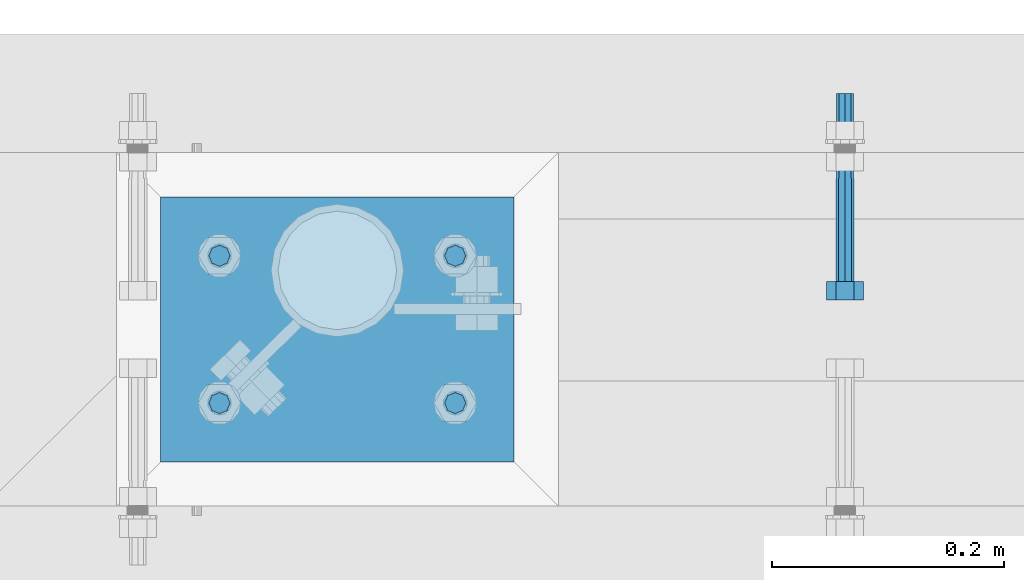
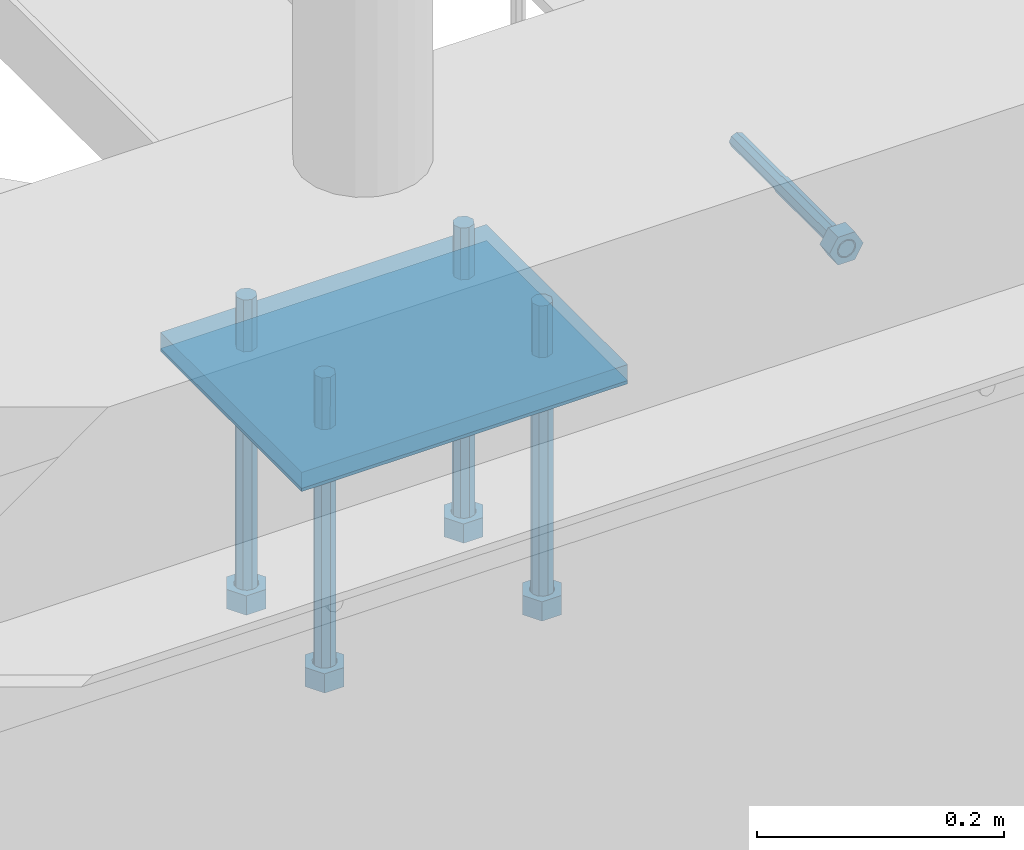
# One storey, part 431 of 975: 7 beams.
"""IFC2X3 building model written with IfcOpenShell, lengths in millimetres."""

from ifc_helpers import new_model, si_unit, frame, origin_with_axes, place, context, subcontext, project, spatial, faceted_brep, material, type_object, element, save


model = new_model("IFC2X3")

# Units and contexts
model_context = context("Model", 3, precision=1e-05, world=origin_with_axes())
body_context = subcontext(model_context, "Body", "Model", "MODEL_VIEW")
ifc_project = project(units=[si_unit("LENGTHUNIT", "METRE", prefix="MILLI"), si_unit("AREAUNIT", "SQUARE_METRE"), si_unit("VOLUMEUNIT", "CUBIC_METRE"), si_unit("MASSUNIT", "GRAM", prefix="KILO"), si_unit("TIMEUNIT", "SECOND"), si_unit("PLANEANGLEUNIT", "RADIAN"), si_unit("SOLIDANGLEUNIT", "STERADIAN"), si_unit("THERMODYNAMICTEMPERATUREUNIT", "DEGREE_CELSIUS"), si_unit("LUMINOUSINTENSITYUNIT", "LUMEN")], contexts=[model_context])

# Site, building, storey
site_placement = place(None, origin_with_axes())
site = spatial("IfcSite", under=ifc_project, at=site_placement, CompositionType="ELEMENT")
building_placement = place(site_placement, origin_with_axes())
building = spatial("IfcBuilding", under=site, at=building_placement, Name="Undefined", CompositionType="ELEMENT")
storey_placement = place(building_placement, origin_with_axes())
storey = spatial("IfcBuildingStorey", under=building, at=storey_placement, Name="Undefined", CompositionType="ELEMENT", Elevation=0.0)

# Beams
ifc_material_1 = material(Name="STEEL/F1554-36")
beam_type_1 = type_object("IfcBeamType", PredefinedType="NOTDEFINED")
beam_1_placement = place(storey_placement, frame((7854.42084018762, 20726.3999996637, 3886.2), z_axis=(0.0, 0.0, 1.0), x_axis=(0.0, -1.0, 0.0)))
element("IfcBeam", 1, at=beam_1_placement, inside=storey, type_object=beam_type_1, material=ifc_material_1, Name="HEADED_ANCHOR_BOLT", context=body_context, shape_type="Brep", body=[
    faceted_brep([(88.9000000184824, 7.94000001861696, -13.7499999799138), (88.8999999527368, 15.8800000758411, 2.00943759409711e-08), (104.774999952569, 15.8800001213949, 6.97191353538074e-08), (104.775000018315, 7.94000006417082, -13.7499999302891), (88.900000064019, -7.94000009583215, -13.7499999799147), (104.775000063852, -7.9400000502792, -13.74999993029), (88.9000000438027, -15.880000153059, 2.00925569515675e-08), (104.775000043643, -15.8800001075042, 6.9716406869702e-08), (88.8999999780608, -7.94000009583488, 13.7500000200998), (104.774999977893, -7.94000005028101, 13.7500000697237), (88.8999999325279, 7.94000001861514, 13.7500000201007), (104.774999932361, 7.940000064169, 13.7500000697246), (88.9000000119959, 3.78780480527439, -7.86545778426807), (88.8999999957159, 6.82538844544797, -5.4430656647246), (88.8999999799416, 8.51112018845743, -1.94260763148395), (88.8999999677944, 8.51112018845652, 1.94260767167179), (88.8999999616899, 6.82538844544615, 5.44306570491244), (88.8999999628249, 3.78780480527257, 7.86545782445592), (88.8999999709849, -3.86089595849626e-08, 8.72999956233434), (88.8999999845473, -3.7878048824914, 7.8654578244541), (88.9000000008309, -6.82538852266407, 5.44306570491153), (88.9000000166052, -8.51112026567444, 1.94260767166998), (88.9000000287488, -8.51112026567353, -1.94260763148577), (88.9000000348606, -6.82538852266407, -5.44306566472642), (88.9000000337182, -3.78780488248958, -7.86545778426898), (88.9000000255583, -3.86080500902608e-08, -8.72999952214832), (104.775000025395, 6.94581103743985e-09, -8.72999947252447), (104.775000011829, 3.78780485082825, -7.86545773464422), (104.774999995549, 6.82538849100092, -5.44306561510075), (104.774999979774, 8.51112023401038, -1.9426075818601), (104.774999967627, 8.51112023401038, 1.94260772129564), (104.774999961523, 6.82538849100092, 5.44306575453629), (104.774999962658, 3.78780485082643, 7.86545787407977), (104.774999970818, 6.94399204803631e-09, 8.7299996119591), (104.77499998438, -3.78780483693754, 7.86545787407886), (104.775000000664, -6.82538847711112, 5.44306575453538), (104.775000016438, -8.51112022012057, 1.94260772129473), (104.775000028581, -8.51112022012057, -1.94260758186101), (104.775000034693, -6.82538847711021, -5.44306561510166), (104.775000033551, -3.78780483693663, -7.86545773464422), (-2.99107341561466e-07, -5.61266007567065, 5.61266007566792), (-4.22995071858168e-07, -7.93750000000728, 0.0), (104.774999998088, -7.93749999999, -4.45652403868735e-11), (104.774999998088, -5.61266007565791, 5.61266007562426), (-1.09139364212751e-11, 1.81898940354586e-12, 7.9375), (104.774999998095, 1.18234311230481e-11, 7.93749999995816), (2.99089151667431e-07, 5.61266007567428, 5.61266007566792), (104.774999998102, 5.61266007568065, 5.61266007562517), (4.22980519942939e-07, 7.93750000001091, 0.0), (104.77499999811, 7.93750000001364, -4.36557456851006e-11), (2.99089151667431e-07, 5.61266007567428, -5.61266007566792), (104.774999998102, 5.61266007568156, -5.61266007571339), (-1.09139364212751e-11, 1.81898940354586e-12, -7.9375), (104.774999998099, 1.2732925824821e-11, -7.93750000004547), (-73.0249999592124, 5.05157065939329, -5.0515715445581), (-73.0249999269472, -1.85405951924622e-07, -7.14400069976364), (-73.0249999328516, -5.0515710302052, -5.05157154455992), (-73.0249999734697, -7.14400018541073, -6.9975976657588e-07), (-73.0250000250016, -5.05157103020611, 5.05157014504039), (-73.0250000572705, -1.85406861419324e-07, 7.1439993002441), (-73.0250000513661, 5.05157065939238, 5.05157014503948), (-73.025000010748, 7.14399981459792, -6.99758857081179e-07), (0.00625003290042514, 5.05157085007795, -5.05157087849238), (0.00625006516929716, 5.27870724909008e-09, -7.1440000336961), (0.00625005926485755, -5.05157083952145, -5.05157087849329), (0.00625001864682417, -7.14399999472516, -3.36940502165817e-08), (0.00624996711121639, -5.05157083952145, 5.05157081110519), (0.00624993484598235, 5.2777977543883e-09, 7.14399996631164), (0.00624994074678398, 5.05157085007704, 5.05157081110701), (0.00624998136845534, 7.14400000528167, -3.36922312271781e-08), (-2.99107341561466e-07, -5.61266007567065, -5.61266007566792), (104.774999998092, -5.612660075657, -5.6126600757143)], [[[0, 1, 2, 3]], [[4, 0, 3, 5]], [[6, 4, 5, 7]], [[8, 6, 7, 9]], [[10, 8, 9, 11]], [[0, 4, 6, 8, 10, 1], [12, 13, 14, 15, 16, 17, 18, 19, 20, 21, 22, 23, 24, 25]], [[12, 25, 26, 27]], [[13, 12, 27, 28]], [[14, 13, 28, 29]], [[15, 14, 29, 30]], [[16, 15, 30, 31]], [[17, 16, 31, 32]], [[18, 17, 32, 33]], [[19, 18, 33, 34]], [[20, 19, 34, 35]], [[21, 20, 35, 36]], [[22, 21, 36, 37]], [[23, 22, 37, 38]], [[24, 23, 38, 39]], [[25, 24, 39, 26]], [[9, 7, 5, 3, 2, 11], [38, 37, 36, 35, 34, 33, 32, 31, 30, 29, 28, 27, 26, 39]], [[1, 10, 11, 2]], [[40, 41, 42, 43]], [[44, 40, 43, 45]], [[46, 44, 45, 47]], [[48, 46, 47, 49]], [[50, 48, 49, 51]], [[52, 50, 51, 53]], [[54, 55, 56, 57, 58, 59, 60, 61]], [[55, 54, 62, 63]], [[56, 55, 63, 64]], [[57, 56, 64, 65]], [[58, 57, 65, 66]], [[59, 58, 66, 67]], [[60, 59, 67, 68]], [[61, 60, 68, 69]], [[54, 61, 69, 62]], [[40, 44, 46, 48, 50, 52, 70, 41], [68, 67, 66, 65, 64, 63, 62, 69]], [[41, 70, 71, 42]], [[53, 51, 49, 47, 45, 43, 42, 71]], [[70, 52, 53, 71]]]),
])
beam_type_2 = type_object("IfcBeamType", PredefinedType="NOTDEFINED")
beam_2_placement = place(storey_placement, frame((7518.40000117523, 20659.7249986259, 3917.95), z_axis=(0.0, -1.0, 0.0), x_axis=(0.0, 0.0, -1.0)))
element("IfcBeam", 2, at=beam_2_placement, inside=storey, type_object=beam_type_2, material=ifc_material_1, Name="HEADED_BOLT", context=body_context, shape_type="Brep", body=[
    faceted_brep([(196.84375, -9.12999965559902, 15.8099993757314), (196.84375, -18.2599997700399, -1.0438852768857e-06), (215.893749999999, -18.2599997700399, -1.0438852768857e-06), (215.893749999999, -9.12999965559902, 15.8099993757314), (196.84375, 9.13000057328281, 15.8099993757314), (215.893749999999, 9.13000057328281, 15.8099993757314), (196.84375, 18.2600006877237, -1.0438852768857e-06), (215.893749999999, 18.2600006877237, -1.0438852768857e-06), (196.84375, 9.13000057328281, -15.810001463502), (215.893749999999, 9.13000057328281, -15.810001463502), (196.84375, -9.12999965559902, -15.810001463502), (215.893749999999, -9.12999965559902, -15.810001463502), (196.84375, -4.47767959644079, 9.2979973979138), (196.84375, -8.06850020163256, 6.43441352102286), (196.84375, -10.0612552973498, 2.29641492663589), (196.84375, -10.0612552973498, -2.29641701440644), (196.84375, -8.06850020163256, -6.43441560879344), (196.84375, -4.47767959644079, -9.29799948568439), (196.84375, 4.58841896033846e-07, -10.3200007387095), (196.84375, 4.47768051412459, -9.29799948568436), (196.84375, 8.06850111931635, -6.43441560879342), (196.84375, 10.0612562150336, -2.29641701440644), (196.84375, 10.0612562150336, 2.29641492663589), (196.84375, 8.06850111931635, 6.43441352102289), (196.84375, 4.47768051412459, 9.29799739791383), (196.84375, 4.58841896033846e-07, 10.3199986509389), (215.893749999999, 4.58841896033846e-07, 10.3199986509389), (215.893749999999, -4.47767959644079, 9.2979973979138), (215.893749999999, -8.06850020163256, 6.43441352102286), (215.893749999999, -10.0612552973498, 2.29641492663589), (215.893749999999, -10.0612552973498, -2.29641701440644), (215.893749999999, -8.06850020163256, -6.43441560879344), (215.893749999999, -4.47767959644079, -9.29799948568439), (215.893749999999, 4.58841896033846e-07, -10.3200007387095), (215.893749999999, 4.47768051412459, -9.29799948568436), (215.893749999999, 8.06850111931635, -6.43441560879342), (215.893749999999, 10.0612562150336, -2.29641701440644), (215.893749999999, 10.0612562150336, 2.29641492663589), (215.893749999999, 8.06850111931635, 6.43441352102289), (215.893749999999, 4.47768051412459, 9.29799739791383), (0.0, -6.73519209080223, 6.73519209080186), (0.0, -9.52499999999964, 0.0), (215.900000000001, -9.52499999999964, 0.0), (215.900000000001, -6.73519209080223, 6.73519209080186), (-9.87109982941227e-13, -1.20792265079217e-13, 9.52499961853027), (215.900000000001, 0.0, 9.52500000000001), (0.0, 6.73519209080223, 6.73519209080186), (215.900000000001, 6.73519209080223, 6.73519209080186), (0.0, 9.52499999999964, 0.0), (215.900000000001, 9.52499999999964, 0.0), (0.0, 6.73519209080223, -6.73519209080186), (215.900000000001, 6.73519209080223, -6.73519209080186), (2.95075507493764e-12, -1.20792265079217e-13, -9.52499961853027), (215.900000000001, 0.0, -9.52500000000001), (-88.9444446471748, -6.3639605718372, 6.39952908988423), (-88.9433906823501, 4.58841896033846e-07, 9.03556784850662), (-88.9444446471748, 6.36396148952099, 6.39952908988423), (-88.9469891433491, 9.0000004588419, 0.0355685678769078), (-88.9495336395235, 6.36396148952099, -6.32839195413041), (-88.9505876043481, 4.58841896033846e-07, -8.9644307127528), (-88.9495336395235, -6.3639605718372, -6.32839195413041), (-88.9469891433491, -8.9999995411581, 0.0355685678769078), (0.0124298302243915, 6.36396148952099, -6.36396152997716), (0.0113758653997138, 4.58841896033846e-07, -9.00000028859955), (0.0124298302243915, -6.3639605718372, -6.36396152997716), (0.0149743263987148, -8.9999995411581, -1.00796984270346e-06), (0.0175188225730381, -6.3639605718372, 6.36395951403748), (0.0185727873977157, 4.58841896033846e-07, 8.99999827265987), (0.0175188225730381, 6.36396148952099, 6.36395951403748), (0.0149743263987148, 9.0000004588419, -1.00796984270346e-06), (0.0, -6.73519209080223, -6.73519209080186), (215.900000000001, -6.73519209080223, -6.73519209080186)], [[[0, 1, 2, 3]], [[4, 0, 3, 5]], [[6, 4, 5, 7]], [[8, 6, 7, 9]], [[10, 8, 9, 11]], [[0, 4, 6, 8, 10, 1], [12, 13, 14, 15, 16, 17, 18, 19, 20, 21, 22, 23, 24, 25]], [[12, 25, 26, 27]], [[13, 12, 27, 28]], [[14, 13, 28, 29]], [[15, 14, 29, 30]], [[16, 15, 30, 31]], [[17, 16, 31, 32]], [[18, 17, 32, 33]], [[19, 18, 33, 34]], [[20, 19, 34, 35]], [[21, 20, 35, 36]], [[22, 21, 36, 37]], [[23, 22, 37, 38]], [[24, 23, 38, 39]], [[25, 24, 39, 26]], [[9, 7, 5, 3, 2, 11], [38, 37, 36, 35, 34, 33, 32, 31, 30, 29, 28, 27, 26, 39]], [[1, 10, 11, 2]], [[40, 41, 42, 43]], [[44, 40, 43, 45]], [[46, 44, 45, 47]], [[48, 46, 47, 49]], [[50, 48, 49, 51]], [[52, 50, 51, 53]], [[54, 55, 56, 57, 58, 59, 60, 61]], [[59, 58, 62, 63]], [[60, 59, 63, 64]], [[61, 60, 64, 65]], [[54, 61, 65, 66]], [[55, 54, 66, 67]], [[56, 55, 67, 68]], [[57, 56, 68, 69]], [[58, 57, 69, 62]], [[40, 44, 46, 48, 50, 52, 70, 41], [68, 67, 66, 65, 64, 63, 62, 69]], [[41, 70, 71, 42]], [[53, 51, 49, 47, 45, 43, 42, 71]], [[70, 52, 53, 71]]]),
])
beam_3_placement = place(storey_placement, frame((7518.40000117523, 20532.7249986259, 3917.95), z_axis=(0.0, -1.0, 0.0), x_axis=(0.0, 0.0, -1.0)))
element("IfcBeam", 3, at=beam_3_placement, inside=storey, type_object=beam_type_2, material=ifc_material_1, Name="HEADED_BOLT", context=body_context, shape_type="Brep", body=[
    faceted_brep([(196.84375, -9.12999965559902, 15.8099993757314), (196.84375, -18.2599997700399, -1.0438852768857e-06), (215.893749999999, -18.2599997700399, -1.0438852768857e-06), (215.893749999999, -9.12999965559902, 15.8099993757314), (196.84375, 9.13000057328281, 15.8099993757314), (215.893749999999, 9.13000057328281, 15.8099993757314), (196.84375, 18.2600006877237, -1.0438852768857e-06), (215.893749999999, 18.2600006877237, -1.0438852768857e-06), (196.84375, 9.13000057328281, -15.810001463502), (215.893749999999, 9.13000057328281, -15.810001463502), (196.84375, -9.12999965559902, -15.810001463502), (215.893749999999, -9.12999965559902, -15.810001463502), (196.84375, -4.47767959644079, 9.2979973979138), (196.84375, -8.06850020163256, 6.43441352102286), (196.84375, -10.0612552973498, 2.29641492663589), (196.84375, -10.0612552973498, -2.29641701440644), (196.84375, -8.06850020163256, -6.43441560879344), (196.84375, -4.47767959644079, -9.29799948568439), (196.84375, 4.58841896033846e-07, -10.3200007387095), (196.84375, 4.47768051412459, -9.29799948568436), (196.84375, 8.06850111931635, -6.43441560879342), (196.84375, 10.0612562150336, -2.29641701440644), (196.84375, 10.0612562150336, 2.29641492663589), (196.84375, 8.06850111931635, 6.43441352102289), (196.84375, 4.47768051412459, 9.29799739791383), (196.84375, 4.58841896033846e-07, 10.3199986509389), (215.893749999999, 4.58841896033846e-07, 10.3199986509389), (215.893749999999, -4.47767959644079, 9.2979973979138), (215.893749999999, -8.06850020163256, 6.43441352102286), (215.893749999999, -10.0612552973498, 2.29641492663589), (215.893749999999, -10.0612552973498, -2.29641701440644), (215.893749999999, -8.06850020163256, -6.43441560879344), (215.893749999999, -4.47767959644079, -9.29799948568439), (215.893749999999, 4.58841896033846e-07, -10.3200007387095), (215.893749999999, 4.47768051412459, -9.29799948568436), (215.893749999999, 8.06850111931635, -6.43441560879342), (215.893749999999, 10.0612562150336, -2.29641701440644), (215.893749999999, 10.0612562150336, 2.29641492663589), (215.893749999999, 8.06850111931635, 6.43441352102289), (215.893749999999, 4.47768051412459, 9.29799739791383), (0.0, -6.73519209080223, 6.73519209080186), (0.0, -9.52499999999964, 0.0), (215.900000000001, -9.52499999999964, 0.0), (215.900000000001, -6.73519209080223, 6.73519209080186), (-9.87109982941227e-13, -1.20792265079217e-13, 9.52499961853027), (215.900000000001, 0.0, 9.52500000000001), (0.0, 6.73519209080223, 6.73519209080186), (215.900000000001, 6.73519209080223, 6.73519209080186), (0.0, 9.52499999999964, 0.0), (215.900000000001, 9.52499999999964, 0.0), (0.0, 6.73519209080223, -6.73519209080186), (215.900000000001, 6.73519209080223, -6.73519209080186), (2.95075507493764e-12, -1.20792265079217e-13, -9.52499961853027), (215.900000000001, 0.0, -9.52500000000001), (-88.9444446471748, -6.3639605718372, 6.39952908988423), (-88.9433906823501, 4.58841896033846e-07, 9.03556784850662), (-88.9444446471748, 6.36396148952099, 6.39952908988423), (-88.9469891433491, 9.0000004588419, 0.0355685678769078), (-88.9495336395235, 6.36396148952099, -6.32839195413041), (-88.9505876043481, 4.58841896033846e-07, -8.9644307127528), (-88.9495336395235, -6.3639605718372, -6.32839195413041), (-88.9469891433491, -8.9999995411581, 0.0355685678769078), (0.0124298302243915, 6.36396148952099, -6.36396152997716), (0.0113758653997138, 4.58841896033846e-07, -9.00000028859955), (0.0124298302243915, -6.3639605718372, -6.36396152997716), (0.0149743263987148, -8.9999995411581, -1.00796984270346e-06), (0.0175188225730381, -6.3639605718372, 6.36395951403748), (0.0185727873977157, 4.58841896033846e-07, 8.99999827265987), (0.0175188225730381, 6.36396148952099, 6.36395951403748), (0.0149743263987148, 9.0000004588419, -1.00796984270346e-06), (0.0, -6.73519209080223, -6.73519209080186), (215.900000000001, -6.73519209080223, -6.73519209080186)], [[[0, 1, 2, 3]], [[4, 0, 3, 5]], [[6, 4, 5, 7]], [[8, 6, 7, 9]], [[10, 8, 9, 11]], [[0, 4, 6, 8, 10, 1], [12, 13, 14, 15, 16, 17, 18, 19, 20, 21, 22, 23, 24, 25]], [[12, 25, 26, 27]], [[13, 12, 27, 28]], [[14, 13, 28, 29]], [[15, 14, 29, 30]], [[16, 15, 30, 31]], [[17, 16, 31, 32]], [[18, 17, 32, 33]], [[19, 18, 33, 34]], [[20, 19, 34, 35]], [[21, 20, 35, 36]], [[22, 21, 36, 37]], [[23, 22, 37, 38]], [[24, 23, 38, 39]], [[25, 24, 39, 26]], [[9, 7, 5, 3, 2, 11], [38, 37, 36, 35, 34, 33, 32, 31, 30, 29, 28, 27, 26, 39]], [[1, 10, 11, 2]], [[40, 41, 42, 43]], [[44, 40, 43, 45]], [[46, 44, 45, 47]], [[48, 46, 47, 49]], [[50, 48, 49, 51]], [[52, 50, 51, 53]], [[54, 55, 56, 57, 58, 59, 60, 61]], [[59, 58, 62, 63]], [[60, 59, 63, 64]], [[61, 60, 64, 65]], [[54, 61, 65, 66]], [[55, 54, 66, 67]], [[56, 55, 67, 68]], [[57, 56, 68, 69]], [[58, 57, 69, 62]], [[40, 44, 46, 48, 50, 52, 70, 41], [68, 67, 66, 65, 64, 63, 62, 69]], [[41, 70, 71, 42]], [[53, 51, 49, 47, 45, 43, 42, 71]], [[70, 52, 53, 71]]]),
])
beam_4_placement = place(storey_placement, frame((7315.20000117522, 20532.7249986259, 3917.95), z_axis=(0.0, -1.0, 0.0), x_axis=(0.0, 0.0, -1.0)))
element("IfcBeam", 4, at=beam_4_placement, inside=storey, type_object=beam_type_2, material=ifc_material_1, Name="HEADED_BOLT", context=body_context, shape_type="Brep", body=[
    faceted_brep([(196.84375, -9.12999965559902, 15.8099993757314), (196.84375, -18.2599997700399, -1.0438852768857e-06), (215.893749999999, -18.2599997700399, -1.0438852768857e-06), (215.893749999999, -9.12999965559902, 15.8099993757314), (196.84375, 9.13000057328281, 15.8099993757314), (215.893749999999, 9.13000057328281, 15.8099993757314), (196.84375, 18.2600006877237, -1.0438852768857e-06), (215.893749999999, 18.2600006877237, -1.0438852768857e-06), (196.84375, 9.13000057328281, -15.810001463502), (215.893749999999, 9.13000057328281, -15.810001463502), (196.84375, -9.12999965559902, -15.810001463502), (215.893749999999, -9.12999965559902, -15.810001463502), (196.84375, -4.47767959644079, 9.2979973979138), (196.84375, -8.06850020163256, 6.43441352102286), (196.84375, -10.0612552973498, 2.29641492663589), (196.84375, -10.0612552973498, -2.29641701440644), (196.84375, -8.06850020163256, -6.43441560879344), (196.84375, -4.47767959644079, -9.29799948568439), (196.84375, 4.58841896033846e-07, -10.3200007387095), (196.84375, 4.47768051412459, -9.29799948568436), (196.84375, 8.06850111931635, -6.43441560879342), (196.84375, 10.0612562150336, -2.29641701440644), (196.84375, 10.0612562150336, 2.29641492663589), (196.84375, 8.06850111931635, 6.43441352102289), (196.84375, 4.47768051412459, 9.29799739791383), (196.84375, 4.58841896033846e-07, 10.3199986509389), (215.893749999999, 4.58841896033846e-07, 10.3199986509389), (215.893749999999, -4.47767959644079, 9.2979973979138), (215.893749999999, -8.06850020163256, 6.43441352102286), (215.893749999999, -10.0612552973498, 2.29641492663589), (215.893749999999, -10.0612552973498, -2.29641701440644), (215.893749999999, -8.06850020163256, -6.43441560879344), (215.893749999999, -4.47767959644079, -9.29799948568439), (215.893749999999, 4.58841896033846e-07, -10.3200007387095), (215.893749999999, 4.47768051412459, -9.29799948568436), (215.893749999999, 8.06850111931635, -6.43441560879342), (215.893749999999, 10.0612562150336, -2.29641701440644), (215.893749999999, 10.0612562150336, 2.29641492663589), (215.893749999999, 8.06850111931635, 6.43441352102289), (215.893749999999, 4.47768051412459, 9.29799739791383), (0.0, -6.73519209080223, 6.73519209080186), (0.0, -9.52499999999964, 0.0), (215.900000000001, -9.52499999999964, 0.0), (215.900000000001, -6.73519209080223, 6.73519209080186), (-9.87109982941227e-13, -1.20792265079217e-13, 9.52499961853027), (215.900000000001, 0.0, 9.52500000000001), (0.0, 6.73519209080223, 6.73519209080186), (215.900000000001, 6.73519209080223, 6.73519209080186), (0.0, 9.52499999999964, 0.0), (215.900000000001, 9.52499999999964, 0.0), (0.0, 6.73519209080223, -6.73519209080186), (215.900000000001, 6.73519209080223, -6.73519209080186), (2.95075507493764e-12, -1.20792265079217e-13, -9.52499961853027), (215.900000000001, 0.0, -9.52500000000001), (-88.9444446471748, -6.3639605718372, 6.39952908988423), (-88.9433906823501, 4.58841896033846e-07, 9.03556784850662), (-88.9444446471748, 6.36396148952099, 6.39952908988423), (-88.9469891433491, 9.0000004588419, 0.0355685678769078), (-88.9495336395235, 6.36396148952099, -6.32839195413041), (-88.9505876043481, 4.58841896033846e-07, -8.9644307127528), (-88.9495336395235, -6.3639605718372, -6.32839195413041), (-88.9469891433491, -8.9999995411581, 0.0355685678769078), (0.0124298302243915, 6.36396148952099, -6.36396152997716), (0.0113758653997138, 4.58841896033846e-07, -9.00000028859955), (0.0124298302243915, -6.3639605718372, -6.36396152997716), (0.0149743263987148, -8.9999995411581, -1.00796984270346e-06), (0.0175188225730381, -6.3639605718372, 6.36395951403748), (0.0185727873977157, 4.58841896033846e-07, 8.99999827265987), (0.0175188225730381, 6.36396148952099, 6.36395951403748), (0.0149743263987148, 9.0000004588419, -1.00796984270346e-06), (0.0, -6.73519209080223, -6.73519209080186), (215.900000000001, -6.73519209080223, -6.73519209080186)], [[[0, 1, 2, 3]], [[4, 0, 3, 5]], [[6, 4, 5, 7]], [[8, 6, 7, 9]], [[10, 8, 9, 11]], [[0, 4, 6, 8, 10, 1], [12, 13, 14, 15, 16, 17, 18, 19, 20, 21, 22, 23, 24, 25]], [[12, 25, 26, 27]], [[13, 12, 27, 28]], [[14, 13, 28, 29]], [[15, 14, 29, 30]], [[16, 15, 30, 31]], [[17, 16, 31, 32]], [[18, 17, 32, 33]], [[19, 18, 33, 34]], [[20, 19, 34, 35]], [[21, 20, 35, 36]], [[22, 21, 36, 37]], [[23, 22, 37, 38]], [[24, 23, 38, 39]], [[25, 24, 39, 26]], [[9, 7, 5, 3, 2, 11], [38, 37, 36, 35, 34, 33, 32, 31, 30, 29, 28, 27, 26, 39]], [[1, 10, 11, 2]], [[40, 41, 42, 43]], [[44, 40, 43, 45]], [[46, 44, 45, 47]], [[48, 46, 47, 49]], [[50, 48, 49, 51]], [[52, 50, 51, 53]], [[54, 55, 56, 57, 58, 59, 60, 61]], [[59, 58, 62, 63]], [[60, 59, 63, 64]], [[61, 60, 64, 65]], [[54, 61, 65, 66]], [[55, 54, 66, 67]], [[56, 55, 67, 68]], [[57, 56, 68, 69]], [[58, 57, 69, 62]], [[40, 44, 46, 48, 50, 52, 70, 41], [68, 67, 66, 65, 64, 63, 62, 69]], [[41, 70, 71, 42]], [[53, 51, 49, 47, 45, 43, 42, 71]], [[70, 52, 53, 71]]]),
])
beam_5_placement = place(storey_placement, frame((7315.20000117522, 20659.7249986259, 3917.95), z_axis=(0.0, -1.0, 0.0), x_axis=(0.0, 0.0, -1.0)))
element("IfcBeam", 5, at=beam_5_placement, inside=storey, type_object=beam_type_2, material=ifc_material_1, Name="HEADED_BOLT", context=body_context, shape_type="Brep", body=[
    faceted_brep([(196.84375, -9.12999965559902, 15.8099993757314), (196.84375, -18.2599997700399, -1.0438852768857e-06), (215.893749999999, -18.2599997700399, -1.0438852768857e-06), (215.893749999999, -9.12999965559902, 15.8099993757314), (196.84375, 9.13000057328281, 15.8099993757314), (215.893749999999, 9.13000057328281, 15.8099993757314), (196.84375, 18.2600006877237, -1.0438852768857e-06), (215.893749999999, 18.2600006877237, -1.0438852768857e-06), (196.84375, 9.13000057328281, -15.810001463502), (215.893749999999, 9.13000057328281, -15.810001463502), (196.84375, -9.12999965559902, -15.810001463502), (215.893749999999, -9.12999965559902, -15.810001463502), (196.84375, -4.47767959644079, 9.2979973979138), (196.84375, -8.06850020163256, 6.43441352102286), (196.84375, -10.0612552973498, 2.29641492663589), (196.84375, -10.0612552973498, -2.29641701440644), (196.84375, -8.06850020163256, -6.43441560879344), (196.84375, -4.47767959644079, -9.29799948568439), (196.84375, 4.58841896033846e-07, -10.3200007387095), (196.84375, 4.47768051412459, -9.29799948568436), (196.84375, 8.06850111931635, -6.43441560879342), (196.84375, 10.0612562150336, -2.29641701440644), (196.84375, 10.0612562150336, 2.29641492663589), (196.84375, 8.06850111931635, 6.43441352102289), (196.84375, 4.47768051412459, 9.29799739791383), (196.84375, 4.58841896033846e-07, 10.3199986509389), (215.893749999999, 4.58841896033846e-07, 10.3199986509389), (215.893749999999, -4.47767959644079, 9.2979973979138), (215.893749999999, -8.06850020163256, 6.43441352102286), (215.893749999999, -10.0612552973498, 2.29641492663589), (215.893749999999, -10.0612552973498, -2.29641701440644), (215.893749999999, -8.06850020163256, -6.43441560879344), (215.893749999999, -4.47767959644079, -9.29799948568439), (215.893749999999, 4.58841896033846e-07, -10.3200007387095), (215.893749999999, 4.47768051412459, -9.29799948568436), (215.893749999999, 8.06850111931635, -6.43441560879342), (215.893749999999, 10.0612562150336, -2.29641701440644), (215.893749999999, 10.0612562150336, 2.29641492663589), (215.893749999999, 8.06850111931635, 6.43441352102289), (215.893749999999, 4.47768051412459, 9.29799739791383), (0.0, -6.73519209080223, 6.73519209080186), (0.0, -9.52499999999964, 0.0), (215.900000000001, -9.52499999999964, 0.0), (215.900000000001, -6.73519209080223, 6.73519209080186), (-9.87109982941227e-13, -1.20792265079217e-13, 9.52499961853027), (215.900000000001, 0.0, 9.52500000000001), (0.0, 6.73519209080223, 6.73519209080186), (215.900000000001, 6.73519209080223, 6.73519209080186), (0.0, 9.52499999999964, 0.0), (215.900000000001, 9.52499999999964, 0.0), (0.0, 6.73519209080223, -6.73519209080186), (215.900000000001, 6.73519209080223, -6.73519209080186), (2.95075507493764e-12, -1.20792265079217e-13, -9.52499961853027), (215.900000000001, 0.0, -9.52500000000001), (-88.9444446471748, -6.3639605718372, 6.39952908988423), (-88.9433906823501, 4.58841896033846e-07, 9.03556784850662), (-88.9444446471748, 6.36396148952099, 6.39952908988423), (-88.9469891433491, 9.0000004588419, 0.0355685678769078), (-88.9495336395235, 6.36396148952099, -6.32839195413041), (-88.9505876043481, 4.58841896033846e-07, -8.9644307127528), (-88.9495336395235, -6.3639605718372, -6.32839195413041), (-88.9469891433491, -8.9999995411581, 0.0355685678769078), (0.0124298302243915, 6.36396148952099, -6.36396152997716), (0.0113758653997138, 4.58841896033846e-07, -9.00000028859955), (0.0124298302243915, -6.3639605718372, -6.36396152997716), (0.0149743263987148, -8.9999995411581, -1.00796984270346e-06), (0.0175188225730381, -6.3639605718372, 6.36395951403748), (0.0185727873977157, 4.58841896033846e-07, 8.99999827265987), (0.0175188225730381, 6.36396148952099, 6.36395951403748), (0.0149743263987148, 9.0000004588419, -1.00796984270346e-06), (0.0, -6.73519209080223, -6.73519209080186), (215.900000000001, -6.73519209080223, -6.73519209080186)], [[[0, 1, 2, 3]], [[4, 0, 3, 5]], [[6, 4, 5, 7]], [[8, 6, 7, 9]], [[10, 8, 9, 11]], [[0, 4, 6, 8, 10, 1], [12, 13, 14, 15, 16, 17, 18, 19, 20, 21, 22, 23, 24, 25]], [[12, 25, 26, 27]], [[13, 12, 27, 28]], [[14, 13, 28, 29]], [[15, 14, 29, 30]], [[16, 15, 30, 31]], [[17, 16, 31, 32]], [[18, 17, 32, 33]], [[19, 18, 33, 34]], [[20, 19, 34, 35]], [[21, 20, 35, 36]], [[22, 21, 36, 37]], [[23, 22, 37, 38]], [[24, 23, 38, 39]], [[25, 24, 39, 26]], [[9, 7, 5, 3, 2, 11], [38, 37, 36, 35, 34, 33, 32, 31, 30, 29, 28, 27, 26, 39]], [[1, 10, 11, 2]], [[40, 41, 42, 43]], [[44, 40, 43, 45]], [[46, 44, 45, 47]], [[48, 46, 47, 49]], [[50, 48, 49, 51]], [[52, 50, 51, 53]], [[54, 55, 56, 57, 58, 59, 60, 61]], [[59, 58, 62, 63]], [[60, 59, 63, 64]], [[61, 60, 64, 65]], [[54, 61, 65, 66]], [[55, 54, 66, 67]], [[56, 55, 67, 68]], [[57, 56, 68, 69]], [[58, 57, 69, 62]], [[40, 44, 46, 48, 50, 52, 70, 41], [68, 67, 66, 65, 64, 63, 62, 69]], [[41, 70, 71, 42]], [[53, 51, 49, 47, 45, 43, 42, 71]], [[70, 52, 53, 71]]]),
])
ifc_material_2 = material(Name="STEEL/A36")
beam_type_3 = type_object("IfcBeamType", PredefinedType="NOTDEFINED")
beam_6_placement = place(storey_placement, frame((7416.80000117522, 20710.5250001518, 3946.525), z_axis=(1.0, 0.0, 0.0), x_axis=(0.0, -1.0, 0.0)))
element("IfcBeam", 6, at=beam_6_placement, inside=storey, type_object=beam_type_3, material=ifc_material_2, Name="PLATE", context=body_context, shape_type="Brep", body=[
    faceted_brep([(0.0, 9.52499999999964, -152.4), (0.0, 9.52499999999964, 152.4), (228.600003051761, 9.52500000000009, 152.4), (228.600003051761, 9.52500000000009, -152.4), (0.0, -9.52499999999964, 152.4), (228.600003051761, -9.52500000000009, 152.4), (0.0, -9.52499999999964, -152.4), (228.600003051761, -9.52500000000009, -152.4)], [[[0, 1, 2, 3]], [[1, 4, 5, 2]], [[4, 6, 7, 5]], [[6, 0, 3, 7]], [[5, 7, 3, 2]], [[6, 4, 1, 0]]]),
])
beam_type_4 = type_object("IfcBeamType", PredefinedType="NOTDEFINED")
beam_7_placement = place(storey_placement, frame((7416.80000117522, 20710.5250001518, 3938.5875), z_axis=(1.0, 0.0, 0.0), x_axis=(0.0, -1.0, 0.0)))
element("IfcBeam", 7, at=beam_7_placement, inside=storey, type_object=beam_type_4, material=ifc_material_2, Name="TEMPLATE", context=body_context, shape_type="Brep", body=[
    faceted_brep([(0.0, 1.58750000000009, -152.4), (0.0, 1.58750000000009, 152.4), (228.600003051761, 1.58750000000009, 152.4), (228.600003051761, 1.58750000000009, -152.4), (0.0, -1.58750000000009, 152.4), (228.600003051761, -1.58750000000009, 152.4), (0.0, -1.58750000000009, -152.4), (228.600003051761, -1.58750000000009, -152.4)], [[[0, 1, 2, 3]], [[1, 4, 5, 2]], [[4, 6, 7, 5]], [[6, 0, 3, 7]], [[5, 7, 3, 2]], [[6, 4, 1, 0]]]),
])

save(model, "model.ifc")
